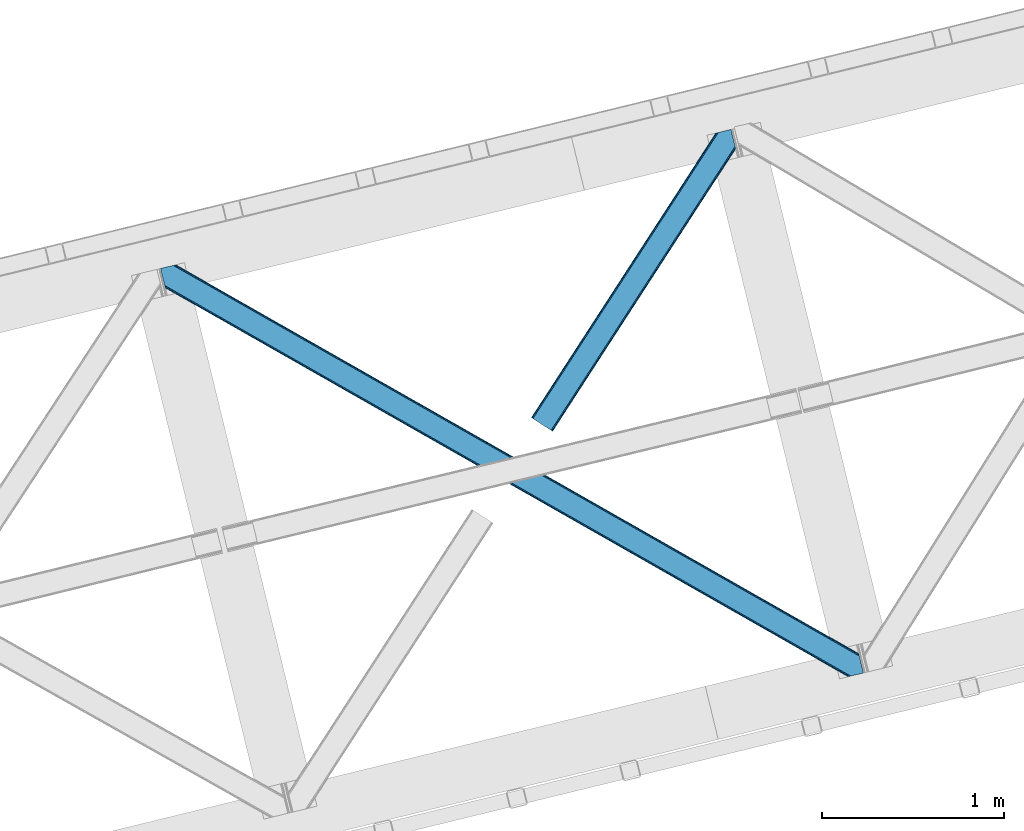
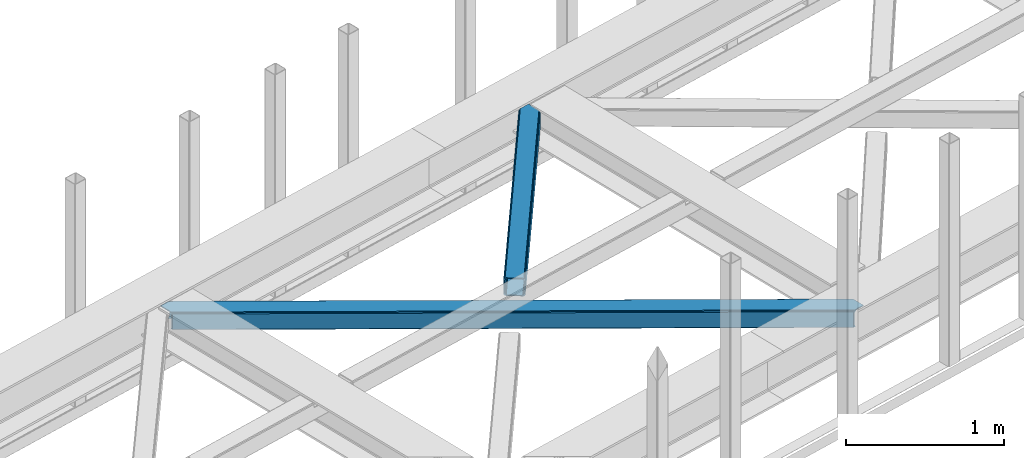
# One storey, part 37 of 67: 2 members.
"""IFC4 building model written with IfcOpenShell, lengths in millimetres."""

from ifc_helpers import new_model, entity, si_unit, converted_unit, derived_unit, direction, frame, origin, place, context, subcontext, project, spatial, triangles, type_object, element, save


model = new_model("IFC4")

# Units and contexts
model_context = context("Model", 3, precision=0.01, world=origin(), true_north=direction((6.12303176911189e-17, 1.0)))
plan_context = context("Plan", 3, precision=0.01, world=origin(), true_north=direction((6.12303176911189e-17, 1.0)))
body_context = subcontext(model_context, "Body", "Model", "MODEL_VIEW")
ifc_project = project(units=[si_unit("LENGTHUNIT", "METRE", prefix="MILLI"), si_unit("AREAUNIT", "SQUARE_METRE"), si_unit("VOLUMEUNIT", "CUBIC_METRE"), converted_unit("PLANEANGLEUNIT", "DEGREE", entity("IfcRatioMeasure", 0.0174532925199433), si_unit("PLANEANGLEUNIT", "RADIAN"), dimensions=[0, 0, 0, 0, 0, 0, 0]), si_unit("MASSUNIT", "GRAM", prefix="KILO"), derived_unit("MASSDENSITYUNIT", [(si_unit("MASSUNIT", "GRAM", prefix="KILO"), 1), (si_unit("LENGTHUNIT", "METRE"), -3)]), derived_unit("MOMENTOFINERTIAUNIT", [(si_unit("LENGTHUNIT", "METRE"), 4)]), si_unit("TIMEUNIT", "SECOND"), si_unit("FREQUENCYUNIT", "HERTZ"), si_unit("THERMODYNAMICTEMPERATUREUNIT", "DEGREE_CELSIUS"), derived_unit("THERMALTRANSMITTANCEUNIT", [(si_unit("MASSUNIT", "GRAM", prefix="KILO"), 1), (si_unit("THERMODYNAMICTEMPERATUREUNIT", "KELVIN"), -1), (si_unit("TIMEUNIT", "SECOND"), -3)]), derived_unit("VOLUMETRICFLOWRATEUNIT", [(si_unit("LENGTHUNIT", "METRE"), 3), (si_unit("TIMEUNIT", "SECOND"), -1)]), derived_unit("MASSFLOWRATEUNIT", [(si_unit("MASSUNIT", "GRAM", prefix="KILO"), 1), (si_unit("TIMEUNIT", "SECOND"), -1)]), derived_unit("ROTATIONALFREQUENCYUNIT", [(si_unit("TIMEUNIT", "SECOND"), -1)]), si_unit("ELECTRICCURRENTUNIT", "AMPERE"), si_unit("ELECTRICVOLTAGEUNIT", "VOLT"), si_unit("POWERUNIT", "WATT"), si_unit("FORCEUNIT", "NEWTON", prefix="KILO"), si_unit("ILLUMINANCEUNIT", "LUX"), si_unit("LUMINOUSFLUXUNIT", "LUMEN"), si_unit("LUMINOUSINTENSITYUNIT", "CANDELA"), derived_unit("USERDEFINED", [(si_unit("MASSUNIT", "GRAM", prefix="KILO"), -1), (si_unit("LENGTHUNIT", "METRE"), -2), (si_unit("TIMEUNIT", "SECOND"), 3), (si_unit("LUMINOUSFLUXUNIT", "LUMEN"), 1)]), derived_unit("LINEARVELOCITYUNIT", [(si_unit("LENGTHUNIT", "METRE"), 1), (si_unit("TIMEUNIT", "SECOND"), -1)]), si_unit("PRESSUREUNIT", "PASCAL"), derived_unit("USERDEFINED", [(si_unit("LENGTHUNIT", "METRE"), -2), (si_unit("MASSUNIT", "GRAM", prefix="KILO"), 1), (si_unit("TIMEUNIT", "SECOND"), -2)]), derived_unit("LINEARFORCEUNIT", [(si_unit("MASSUNIT", "GRAM", prefix="KILO"), 1), (si_unit("LENGTHUNIT", "METRE"), 1), (si_unit("TIMEUNIT", "SECOND"), -2), (si_unit("LENGTHUNIT", "METRE"), -1)]), derived_unit("PLANARFORCEUNIT", [(si_unit("MASSUNIT", "GRAM", prefix="KILO"), 1), (si_unit("LENGTHUNIT", "METRE"), 1), (si_unit("TIMEUNIT", "SECOND"), -2), (si_unit("LENGTHUNIT", "METRE"), -2)])], contexts=[model_context, plan_context])

# Site, building, storey
site_placement = place(None, origin())
site = spatial("IfcSite", under=ifc_project, at=site_placement, CompositionType="ELEMENT")
building_placement = place(site_placement, origin())
building = spatial("IfcBuilding", under=site, at=building_placement, CompositionType="ELEMENT")
storey_placement = place(building_placement, frame((0.0, 0.0, 19800.0)))
storey = spatial("IfcBuildingStorey", under=building, at=storey_placement, CompositionType="ELEMENT", Elevation=19800.0)

# Members
member_type_1 = type_object("IfcMemberType", PredefinedType="BRACE")
member_1_placement = place(storey_placement, frame((-33302.3207519531, 10419.121005249, 3823.05807495117)))
element("IfcMember", 1, at=member_1_placement, inside=storey, type_object=member_type_1, ObjectType="Steel Horizontal Brace", PredefinedType="BRACE", context=body_context, shape_type="Tessellation", body=[
    triangles([(3770.60705566406, 0.0, 122.478570556643), (3772.49298706055, 0.459274291992188, 129.175836181643), (25.7193603515625, 2133.71162109375, 130.119964599609), (26.1542175292998, 2131.93149719238, 123.422698974609), (3777.86242675781, 1.767333984375, 134.852233886719), (24.4845520019517, 2138.77991638184, 135.79868774414), (3785.89449462891, 3.72651672363281, 138.645025634767), (22.6358276367173, 2146.36666259766, 139.593804931643), (3795.37298583984, 6.03684082031214, 139.975177001954), (20.454565429689, 2155.31379089356, 140.926281738281), (1898.4864440918, 1065.90586853027, 17.9500671386741), (2530.61995239258, 705.99644165039, 17.7919372558608), (3162.75346069336, 346.087014770508, 17.631481933593), (3770.60705566406, 0.0, 17.478002929689), (1266.35293579102, 1425.81529541016, 18.1105224609382), (26.1542175292998, 2131.93149719238, 18.4221313476555), (634.22175292969, 1785.72355957031, 18.2686523437515), (3834.64500732422, 104.50408630371, 139.977502441408), (3855.09957275391, 20.5952545166019, 139.963549804688), (59.7242614746137, 2253.78103637695, 140.93093261719), (0.0, 2239.22262268066, 140.940234375001), (3832.46607055664, 113.452377319336, 138.647351074218), (69.2027526855454, 2256.09136047363, 139.596130371094), (3830.61502075195, 121.037960815429, 134.854559326173), (77.2371459960923, 2258.04938049316, 135.801013183594), (3829.38021240235, 126.106256103516, 129.178161621094), (82.6065856933637, 2259.35860290527, 130.122290039064), (3828.94535522461, 127.886380004882, 122.480895996094), (84.490191650395, 2259.81787719727, 123.425024414064), (3220.89642333984, 474.082690429686, 17.6338073730476), (3828.94535522461, 127.886380004882, 17.4803283691399), (2588.76291503906, 833.99211730957, 17.7942626953118), (1956.62940673828, 1193.90154418945, 17.9547180175796), (1324.4958984375, 1553.81097106934, 18.1128479003928), (692.364715576172, 1913.72156066894, 18.273303222657), (84.490191650395, 2259.81787719727, 18.4267822265647), (3832.89627685547, 111.685043334961, 127.852661132813), (3832.89627685547, 111.685043334961, 12.1039123535156), (3833.99853515625, 107.15973815918, 9.46221313476781), (3829.58020019531, 125.287701416015, 9.46221313476781), (3831.65914306641, 116.753338623046, 122.176263427737), (3834.7450012207, 104.098297119141, 131.645452880861), (3836.92626342774, 95.1500061035149, 132.975604248048), (3855.09957275391, 20.5952545166019, 132.963977050782), (3831.22661132813, 118.533462524414, 115.478997802737), (3831.22661132813, 118.533462524414, 24.4799011230461), (3831.65914306641, 116.753338623046, 17.7826354980461), (3829.47090454102, 125.737673950194, 10.8528259277336), (1952.50407714844, 1188.19607849121, 24.9542907714858), (74.5838195800825, 2257.4029083252, 116.427777099609), (2588.61641235352, 826.021673583984, 24.793835449218), (3224.72874755859, 463.846105957031, 24.6333801269539), (1316.39406738281, 1550.37164611816, 25.11474609375), (74.5838195800825, 2257.4029083252, 25.4263549804709), (680.279406738282, 1912.54721374512, 25.2752014160178), (72.7002136230512, 2256.9436340332, 123.125042724609), (67.3307739257798, 2255.63557434082, 128.803765869143), (59.2940551757856, 2253.67639160156, 132.598883056642), (49.8202148437485, 2251.36723022461, 133.931359863283), (0.0, 2239.22262268066, 133.940661621094), (67.3307739257798, 2255.63557434082, 13.0550170898459), (81.762451171875, 2259.1539642334, 10.4412231445313), (72.7002136230512, 2256.9436340332, 18.7314147949219), (62.6054809570342, 2254.4833190918, 10.4412231445313), (82.2252136230454, 2259.26558532715, 11.7946289062493), (3805.27935791016, 8.45180969238208, 132.973278808593), (18.1733093261719, 2164.66787109375, 133.929034423829), (3795.80319213867, 6.14148559570276, 131.643127441406), (20.3545715332075, 2155.71958007812, 132.594232177737), (3787.76879882813, 4.18230285644495, 127.850335693362), (22.2032958984419, 2148.13399658203, 128.799114990234), (3782.39935913086, 2.87424316406214, 122.173937988282), (23.4404296875, 2143.06453857422, 123.122717285158), (3780.51342773438, 2.41496887206995, 115.476672363282), (23.8729614257827, 2141.28441467285, 116.425451660158), (3174.86434936523, 347.246246337891, 24.6287292480483), (3780.51342773438, 2.41496887206995, 24.4775756835952), (2538.75433959961, 709.420651245116, 24.7891845703125), (1902.64200439453, 1071.59505615234, 24.9496398925803), (1266.52966918945, 1433.76946105957, 25.1100952148445), (630.417333984376, 1795.9438659668, 25.2705505371086), (23.8729614257827, 2141.28441467285, 25.4240295410164), (23.4404296875, 2143.06453857422, 18.7267639160164), (25.526348876956, 2134.50575866699, 10.4412231445313), (22.2032958984419, 2148.13399658203, 13.0503662109368), (25.6333190918012, 2134.06973876953, 11.7923034667983), (21.1173156738296, 2152.58837585449, 10.4412231445313), (3787.76879882813, 4.18230285644495, 12.1015869140647), (3773.35805053711, 0.669726562498909, 9.46221313476781), (3782.39935913086, 2.87424316406214, 17.7803100585952), (3792.55455322266, 5.34967346191297, 9.46221313476781), (3772.88133544922, 0.554617309569949, 10.8481750488281), (3697.37896728516, 59.5847351074208, 9.46221313476781), (3701.80660400391, 41.4207275390618, 9.46221313476781), (153.281341552734, 2218.44482116699, 10.4412231445313), (157.68107299805, 2200.39708557129, 10.4412231445313), (154.658001708987, 2217.02514038086, 9.4412841796875), (159.494915771487, 2197.17402648926, 9.4412841796875), (159.143774414064, 2198.29140014648, 9.82498168945313), (154.325463867186, 2217.3681427002, 9.68312988281468), (158.657757568362, 2198.98903198242, 10.0296203613289), (153.969671630861, 2217.73439941406, 9.94125366210938), (158.167089843751, 2199.69829101562, 10.2365844726555), (153.613879394536, 2218.10181884766, 10.1993774414077), (193.244018554688, 2054.50599060059, 10.4412231445313), (197.636773681639, 2036.48848571777, 10.4412231445313), (193.823052978514, 2056.35122680664, 9.4412841796875), (198.650665283203, 2036.54313354492, 9.4412841796875), (193.769567871095, 2055.7105682373, 9.74824218749927), (198.466955566408, 2036.45825500488, 9.74126586914281), (193.713757324222, 2055.05479431152, 10.0598510742202), (198.266967773438, 2036.36523742676, 10.0668273925803), (193.657946777348, 2054.41297302246, 10.366809082032), (198.078607177733, 2036.27919616699, 10.366809082032), (3701.47406616211, 41.764892578125, 9.22036743164063), (3696.87899780273, 60.0172668457035, 9.38547363281396), (3701.11827392578, 42.1334747314449, 8.96224365234593), (3696.43716430664, 60.9648834228519, 9.07851562500218), (3700.76248168945, 42.5032196044922, 8.7041198730476), (3695.99067993164, 61.9218017578114, 8.76923217773583), (3700.42994384766, 42.8473846435536, 8.46227416992406), (3695.54884643555, 62.8694183349598, 8.46227416992406), (3163.41156005859, 347.245083618163, 10.934216308593), (634.879852294922, 1786.8827911377, 11.5737121582024), (636.754156494142, 1790.1791015625, 5.89498901367188), (197.780950927736, 2040.11268310547, 6.0066101074226), (3165.28586425781, 350.542556762695, 5.25781860351708), (3699.57883300781, 46.3401947021484, 5.1229431152351), (3697.72778320313, 53.9257781982415, 1.33015136718677), (3168.09499511719, 355.4759765625, 1.46502685546875), (3695.5465209961, 62.8740692138672, 0.0), (3171.40874633789, 361.296551513671, 0.132550048827397), (642.877038574221, 1800.9342590332, 0.76972045898583), (639.563287353518, 1795.11368408203, 2.10219726562718), (195.932226562501, 2047.69826660156, 2.21381835937427), (193.750964355473, 2056.64655761719, 0.8836669921875), (2539.27523803711, 721.205978393555, 0.290679931640625), (2535.96148681641, 715.385403442382, 1.62315673828198), (1907.14172973633, 1081.11540527344, 0.451135253908433), (1903.82797851563, 1075.29483032227, 1.78361206054615), (1275.00822143555, 1441.02483215332, 0.609265136718022), (1271.69447021485, 1435.20425720215, 1.94174194335938), (2533.15235595703, 710.451983642577, 5.41594848633031), (1901.01884765625, 1070.36141052246, 5.57640380859448), (1268.88766479492, 1430.27083740234, 5.73685913085865), (2531.27805175781, 707.154510498047, 11.0946716308608), (1899.14454345703, 1067.06393737793, 11.2528015136741), (1267.01103515625, 1426.97336425781, 11.4132568359382), (3661.34860839844, 203.171319580078, 0.0209289550803078), (3212.23416137695, 458.877804565429, 0.134875488281978), (2580.10297851563, 818.787231445313, 0.293005371095205), (1947.96947021484, 1178.69665832519, 0.453460693359375), (683.702453613281, 1898.51551208496, 0.772045898436772), (1315.83596191406, 1538.60608520508, 0.613916015627183), (159.553051757815, 2196.9438079834, 0.904595947267808), (3177.39675292969, 351.70062561035, 12.2550659179688), (3180.20588378907, 356.635208129883, 8.46227416992406), (3695.44420166016, 63.299624633788, 8.39483642578125), (3693.26759033203, 72.2269866943352, 7.00189819336083), (639.072619628907, 1811.15340270996, 7.77161865234302), (191.472033691411, 2065.99947509766, 7.88323974609375), (193.643994140628, 2057.08722839356, 9.32268676758031), (632.952062988283, 1800.39940795898, 12.8968872070327), (635.758868408204, 1805.33399047852, 9.10409545898438), (631.075433349612, 1797.10309753418, 18.5756103515632), (3183.51963500977, 362.455783081054, 7.12979736328271), (3175.52244873047, 348.404315185546, 17.9337890624993), (2539.41011352539, 710.578720092773, 18.0942443847671), (1903.30010375977, 1072.753125, 18.2546997070313), (1267.18776855469, 1434.92752990723, 18.4151550292991), (2541.28674316406, 713.876193237304, 12.4155212402366), (1905.17440795898, 1076.05059814453, 12.5759765625007), (1269.06439819336, 1438.22500305176, 12.7364318847649), (2544.09587402344, 718.810775756836, 8.62272949218823), (1907.98353881836, 1080.98518066406, 8.7831848144524), (1271.87352905274, 1443.15958557129, 8.94364013672021), (2547.40962524414, 724.630187988281, 7.29025268554688), (1911.29729003906, 1086.80459289551, 7.45070800781468), (1275.18495483399, 1448.97899780273, 7.61116333007885), (155.520739746098, 2213.47884521484, 6.03218994140843), (157.37178955078, 2205.89209899902, 2.23707275390552), (161.831982421878, 2187.59089050293, 7.90416870117406), (159.657696533206, 2196.50778808594, 9.33431396484593), (3216.0664855957, 448.640057373046, 7.13212280273365), (2579.95647583008, 810.815624999999, 7.29257812500146), (1943.84181518555, 1172.99119262695, 7.45303344726563), (3663.6275390625, 193.818402099609, 7.02050170898656), (671.617144775391, 1897.34000244141, 7.7739440917976), (1307.72947998047, 1535.16559753418, 7.61348876953343), (3220.23832397461, 472.926947021484, 10.9365417480476), (3218.35704345703, 469.630636596679, 5.26014404296802), (3656.48843994141, 223.423571777343, 8.84597167968968), (3656.47216186524, 223.174749755859, 8.46227416992406), (3657.48372802735, 223.244512939453, 9.46221313476781), (3656.81400146485, 223.365435791015, 9.04595947265625), (3657.31862182617, 219.705194091797, 5.14852294922093), (691.704290771486, 1912.56465454101, 11.576037597657), (689.82533569336, 1909.26834411621, 5.89731445312646), (687.016204833984, 1904.33492431641, 2.10452270507813), (3659.16734619141, 212.119610595702, 1.3557312011726), (3215.54791259766, 464.697216796874, 1.46735229492333), (2588.10481567383, 832.836373901368, 11.0969970703118), (1955.97130737305, 1192.74580078125, 11.2574523925796), (1323.83779907227, 1552.65522766113, 11.4155822753928), (2586.22353515625, 829.540063476563, 5.42059936523583), (1954.09235229492, 1189.44949035644, 5.57872924804906), (1321.95884399414, 1549.35891723633, 5.73918457031323), (2583.41440429688, 824.606643676758, 1.62548217773656), (1951.28322143555, 1184.51607055664, 1.78593750000073), (1319.14971313477, 1544.42549743652, 1.94406738281396), (674.930895996094, 1903.16057739258, 9.10642089843896), (677.742352294925, 1908.09399719238, 12.8992126464836), (3661.36256103516, 203.10969543457, 8.46227416992406), (3661.92066650391, 205.049111938477, 9.46221313476781), (3222.19169311524, 459.394052124024, 12.2573913574233), (3219.38023681641, 454.459469604491, 8.464599609375), (3661.30209960938, 203.975921630859, 8.81574096679833), (3661.24396362305, 204.843310546874, 9.1692077636726), (679.618981933596, 1911.38914489746, 18.5779357910178), (3224.06832275391, 462.689199829101, 17.9361145019539), (2583.26790161133, 816.635037231445, 8.62505493164281), (1947.15556640625, 1178.8106048584, 8.78551025390698), (1311.04323120117, 1540.98500976563, 8.94596557617115), (2586.0770324707, 821.56845703125, 12.4178466796875), (1949.96469726563, 1183.74286193848, 12.5783020019553), (1313.8546875, 1545.91842956543, 12.7387573242195), (2587.95598754883, 824.864767456054, 18.096569824218), (1951.84365234375, 1187.04033508301, 18.2570251464858), (1315.73131713867, 1549.21473999023, 18.41748046875)], [[1, 2, 3], [3, 4, 1], [2, 5, 6], [6, 3, 2], [5, 7, 8], [8, 6, 5], [7, 9, 10], [10, 8, 7], [11, 1, 4], [1, 12, 13], [11, 12, 1], [13, 14, 1], [15, 11, 4], [4, 16, 17], [17, 15, 4], [9, 18, 10], [9, 19, 18], [20, 10, 18], [21, 10, 20], [18, 22, 23], [23, 20, 18], [22, 24, 25], [25, 23, 22], [24, 26, 27], [27, 25, 24], [26, 28, 29], [29, 27, 26], [30, 28, 31], [28, 30, 32], [28, 33, 29], [33, 28, 32], [29, 33, 34], [34, 35, 29], [36, 29, 35], [37, 24, 22], [38, 39, 40], [24, 37, 41], [42, 37, 22], [42, 18, 43], [19, 43, 18], [43, 19, 44], [42, 22, 18], [31, 45, 46], [40, 47, 38], [47, 31, 46], [48, 47, 40], [48, 31, 47], [28, 45, 31], [41, 26, 24], [28, 26, 41], [45, 28, 41], [49, 45, 50], [45, 51, 52], [49, 51, 45], [52, 46, 45], [53, 49, 50], [50, 54, 55], [55, 53, 50], [45, 41, 50], [56, 50, 41], [41, 37, 56], [57, 56, 37], [37, 42, 57], [58, 57, 42], [42, 43, 58], [59, 58, 43], [56, 29, 27], [58, 23, 20], [21, 59, 20], [59, 21, 60], [59, 58, 20], [57, 23, 58], [57, 56, 25], [25, 23, 57], [27, 25, 56], [54, 36, 29], [61, 62, 63], [56, 50, 29], [61, 64, 62], [54, 63, 36], [50, 54, 29], [65, 36, 63], [63, 62, 65], [43, 66, 67], [66, 43, 44], [67, 59, 43], [60, 59, 67], [66, 68, 67], [69, 67, 68], [68, 70, 69], [71, 69, 70], [70, 72, 71], [73, 71, 72], [72, 74, 73], [75, 73, 74], [76, 74, 77], [74, 76, 78], [74, 79, 75], [79, 74, 78], [75, 79, 80], [80, 81, 75], [82, 75, 81], [83, 84, 85], [82, 4, 16], [16, 86, 83], [86, 84, 83], [83, 82, 16], [75, 4, 82], [73, 71, 6], [3, 73, 6], [3, 4, 73], [75, 73, 4], [71, 8, 6], [69, 8, 71], [87, 85, 84], [69, 67, 10], [69, 10, 8], [67, 21, 10], [67, 60, 21], [72, 1, 2], [68, 7, 9], [66, 19, 44], [9, 66, 68], [66, 9, 19], [70, 7, 68], [70, 72, 5], [5, 7, 70], [2, 5, 72], [14, 1, 74], [88, 89, 90], [72, 74, 1], [88, 91, 89], [77, 90, 14], [77, 14, 74], [92, 14, 90], [90, 89, 92], [91, 89, 93], [94, 93, 89], [95, 96, 62], [64, 62, 96], [97, 98, 99], [100, 99, 101], [102, 101, 103], [104, 103, 96], [96, 95, 104], [103, 104, 102], [101, 102, 100], [99, 100, 97], [105, 106, 84], [84, 87, 105], [107, 108, 109], [110, 109, 108], [109, 110, 111], [112, 111, 110], [111, 112, 113], [114, 113, 112], [113, 114, 106], [106, 105, 113], [115, 116, 93], [117, 118, 116], [119, 120, 118], [121, 122, 120], [120, 119, 121], [118, 117, 119], [116, 115, 117], [93, 94, 115], [123, 92, 14], [124, 17, 16], [110, 125, 112], [110, 108, 125], [114, 112, 125], [108, 126, 125], [124, 86, 106], [106, 125, 124], [106, 114, 125], [86, 84, 106], [92, 123, 94], [123, 127, 128], [128, 121, 123], [115, 123, 117], [115, 94, 123], [123, 119, 117], [123, 121, 119], [94, 89, 92], [129, 128, 127], [127, 130, 129], [131, 129, 130], [130, 132, 131], [133, 134, 135], [135, 136, 133], [134, 125, 126], [126, 135, 134], [16, 86, 124], [14, 13, 123], [132, 130, 137], [138, 137, 130], [137, 138, 139], [140, 139, 138], [139, 140, 141], [142, 141, 140], [141, 142, 133], [134, 133, 142], [130, 127, 143], [143, 138, 130], [138, 143, 144], [144, 140, 138], [140, 144, 145], [145, 142, 140], [142, 145, 125], [125, 134, 142], [127, 123, 143], [146, 143, 123], [143, 146, 144], [147, 144, 146], [144, 147, 145], [148, 145, 147], [145, 148, 125], [124, 125, 148], [123, 13, 12], [12, 146, 123], [146, 12, 11], [11, 147, 146], [147, 11, 15], [15, 148, 147], [148, 15, 17], [17, 124, 148], [149, 131, 132], [150, 132, 137], [132, 150, 149], [151, 139, 152], [137, 151, 150], [151, 137, 139], [133, 153, 154], [152, 141, 154], [141, 152, 139], [141, 133, 154], [136, 153, 133], [155, 153, 136], [156, 116, 118], [118, 157, 156], [118, 120, 157], [122, 157, 120], [122, 158, 157], [88, 91, 93], [93, 156, 88], [93, 116, 156], [157, 158, 159], [160, 161, 162], [163, 113, 105], [105, 85, 163], [105, 87, 85], [164, 162, 107], [107, 163, 164], [163, 109, 111], [109, 163, 107], [111, 113, 163], [81, 165, 82], [83, 82, 165], [165, 163, 83], [85, 83, 163], [162, 164, 160], [159, 166, 157], [90, 88, 156], [156, 167, 90], [77, 90, 167], [167, 76, 77], [76, 167, 168], [168, 78, 76], [78, 168, 79], [169, 79, 168], [79, 169, 80], [170, 80, 169], [80, 170, 81], [165, 81, 170], [167, 156, 168], [171, 168, 156], [168, 171, 172], [172, 169, 168], [169, 172, 173], [173, 170, 169], [170, 173, 163], [163, 165, 170], [156, 157, 174], [174, 171, 156], [171, 174, 172], [175, 172, 174], [172, 175, 173], [176, 173, 175], [173, 176, 163], [164, 163, 176], [157, 166, 174], [177, 174, 166], [174, 177, 178], [178, 175, 174], [175, 178, 179], [179, 176, 175], [176, 179, 160], [160, 164, 176], [98, 180, 181], [155, 98, 181], [182, 183, 155], [182, 155, 161], [180, 98, 97], [155, 183, 98], [161, 136, 162], [136, 135, 107], [136, 161, 155], [126, 107, 135], [136, 107, 162], [126, 108, 107], [177, 166, 184], [184, 185, 177], [185, 178, 177], [178, 185, 186], [166, 187, 184], [166, 159, 187], [188, 160, 189], [160, 188, 161], [182, 161, 188], [179, 189, 160], [186, 179, 178], [189, 179, 186], [190, 30, 31], [191, 192, 193], [190, 48, 194], [194, 191, 190], [194, 195, 191], [48, 40, 194], [193, 196, 191], [65, 197, 95], [197, 198, 180], [180, 97, 197], [197, 97, 102], [102, 95, 197], [197, 65, 36], [36, 35, 197], [95, 62, 65], [198, 199, 181], [181, 180, 198], [199, 153, 155], [155, 181, 199], [200, 149, 150], [150, 201, 200], [196, 200, 201], [201, 191, 196], [31, 48, 190], [30, 190, 32], [202, 32, 190], [32, 202, 33], [203, 33, 202], [33, 203, 34], [204, 34, 203], [34, 204, 197], [197, 35, 34], [190, 191, 205], [205, 202, 190], [202, 205, 206], [206, 203, 202], [203, 206, 207], [207, 204, 203], [204, 207, 198], [198, 197, 204], [191, 201, 205], [208, 205, 201], [205, 208, 206], [209, 206, 208], [206, 209, 207], [210, 207, 209], [207, 210, 198], [199, 198, 210], [201, 150, 208], [151, 208, 150], [208, 151, 152], [152, 209, 208], [209, 152, 154], [154, 210, 209], [210, 154, 153], [153, 199, 210], [211, 99, 183], [212, 103, 101], [212, 96, 103], [101, 211, 212], [101, 99, 211], [61, 64, 96], [96, 212, 61], [211, 183, 182], [184, 187, 213], [214, 38, 215], [214, 39, 38], [213, 215, 216], [217, 218, 215], [215, 213, 217], [213, 216, 184], [182, 188, 211], [212, 219, 63], [63, 61, 212], [219, 55, 54], [54, 63, 219], [47, 46, 220], [52, 220, 46], [38, 47, 215], [220, 215, 47], [184, 216, 185], [221, 185, 216], [185, 221, 186], [222, 186, 221], [186, 222, 189], [223, 189, 222], [189, 223, 188], [211, 188, 223], [216, 215, 224], [224, 221, 216], [221, 224, 225], [225, 222, 221], [222, 225, 226], [226, 223, 222], [223, 226, 212], [212, 211, 223], [215, 220, 224], [227, 224, 220], [224, 227, 225], [228, 225, 227], [225, 228, 226], [229, 226, 228], [226, 229, 212], [219, 212, 229], [220, 52, 51], [51, 227, 220], [227, 51, 49], [49, 228, 227], [228, 49, 53], [53, 229, 228], [229, 53, 55], [55, 219, 229], [149, 187, 159], [213, 196, 193], [149, 213, 187], [213, 200, 196], [213, 149, 200], [131, 149, 159], [158, 131, 159], [128, 158, 121], [158, 129, 131], [158, 128, 129], [214, 217, 193], [217, 213, 193], [40, 39, 214], [214, 194, 40]]),
])
member_type_2 = type_object("IfcMemberType", PredefinedType="BRACE")
member_2_placement = place(storey_placement, frame((-31269.0378845215, 11764.6853851318, 3823.57664794922)))
element("IfcMember", 2, at=member_2_placement, inside=storey, type_object=member_type_2, ObjectType="Steel Horizontal Brace", PredefinedType="BRACE", context=body_context, shape_type="Tessellation", body=[
    triangles([(972.968518066409, 1545.29288635254, 0.386022949220205), (1007.16875610352, 1404.99563598633, 0.365093994139897), (14.7014282226592, 66.6447692871097, 0.0), (102.814654541016, 9.54011535644531, 0.0), (1.13248901367479, 75.4349304199222, 10.8039916992202), (0.011627197265625, 76.1581420898438, 17.4989318847656), (1010.67784423828, 1635.6559753418, 17.9082092285171), (968.503674316409, 1566.80901489258, 9.6808044433601), (4.31601562500146, 73.3734283447266, 5.12526855468604), (968.640875244142, 1567.26712646485, 9.92265014648365), (968.357171630862, 1566.32067260742, 9.42268066406177), (968.210668945314, 1565.83116760254, 9.16455688476708), (968.073468017581, 1565.37421875, 8.9227111816399), (968.938531494143, 1561.82676086426, 5.51361694336083), (1012.94282226563, 1636.20826721191, 11.2760559082017), (1013.40325927734, 1636.32105102539, 9.92265014648365), (970.787255859377, 1554.24117736817, 1.71849975585792), (9.07851562500218, 70.2864074707031, 1.33247680664135), (1010.67784423828, 1635.6559753418, 122.906451416016), (0.0, 76.1395385742198, 122.499499511719), (1012.56145019531, 1636.11524963379, 129.603717041016), (1.11853637695458, 75.4140014648438, 129.196765136719), (1017.92856445313, 1637.42330932617, 135.282440185547), (4.29973754883031, 73.3490112304698, 134.873162841795), (1025.96528320313, 1639.38249206543, 139.077557373046), (9.06456298828198, 70.2608276367191, 138.668280029298), (1035.44377441406, 1641.69281616211, 140.412359619142), (14.6828247070334, 66.6191894531257, 140.000756835936), (973.040606689454, 1549.21939086914, 9.92265014648365), (972.796435546876, 1548.6089630127, 9.84823608398438), (972.833642578127, 1547.58344421387, 9.5412780761726), (972.87317504883, 1546.54862365723, 9.22966918945167), (972.912707519532, 1545.5231048584, 8.9227111816399), (1032.56255493164, 1640.99053344727, 9.92265014648365), (14.9525756835938, 66.4773376464855, 8.3320495605476), (20.5754882812507, 62.8368621826176, 6.99957275390625), (975.249774169923, 1535.93996887207, 7.38559570312646), (10.1877502441421, 69.5655212402344, 12.1248413085923), (1027.83726196289, 1639.83827819824, 12.5364440917983), (973.075488281251, 1544.85570373535, 8.81574096679833), (1022.46782226563, 1638.53021850586, 18.2128417968743), (1020.58421630859, 1638.07094421387, 24.9077819824233), (7.00422363281541, 71.6270233154301, 17.8035644531265), (5.88568725586083, 72.3502349853516, 24.5008300781265), (1004.8875, 1414.3485534668, 7.36466674804615), (96.9382690429702, 13.3456970214847, 6.99957275390625), (1007.06178588867, 1405.4363067627, 8.80411376953271), (1007.24084472656, 1404.70030517578, 8.9227111816399), (1012.06845703125, 1384.89221191406, 8.9227111816399), (1011.19874267578, 1388.46176147461, 5.488037109375), (1009.35001831055, 1396.0473449707, 1.69524536132667), (1020.58421630859, 1638.07094421387, 115.909204101561), (5.87638549804979, 72.3339569091804, 115.499926757813), (1035.87398071289, 1641.7974609375, 132.080310058594), (1045.34782104492, 1644.10778503418, 133.412786865236), (20.5592102050796, 62.8124450683608, 132.998858642579), (14.9386230468772, 66.4552459716797, 131.668707275392), (1027.83726196289, 1639.83827819824, 128.285192871095), (10.1737976074219, 69.5434295654304, 127.873590087889), (1022.46782226563, 1638.53021850586, 122.606469726561), (6.99259643554979, 71.6084197998061, 122.197192382813), (1095.16803588867, 1656.2512298584, 140.421661376953), (1095.16803588867, 1656.2512298584, 133.422088623047), (1115.62260131836, 1572.34239807129, 140.407708740233), (102.798376464845, 9.5145355224613, 140.000756835936), (1113.34134521485, 1581.69647827149, 133.410461425781), (96.92431640625, 13.3224426269535, 132.998858642579), (1117.80153808594, 1563.39526977539, 139.075231933595), (108.418963623048, 5.87289733886792, 138.668280029298), (1119.65258789063, 1555.80852355957, 135.280114746092), (113.181463623048, 2.78587646484448, 134.873162841795), (1120.88739624024, 1550.74022827148, 129.601391601562), (116.36731567383, 0.72321166992333, 129.196765136719), (1121.32225341797, 1548.96010437012, 122.904125976562), (117.485852050784, 0.0, 122.499499511719), (1121.32225341797, 1548.96010437012, 17.9035583496079), (117.499804687501, 0.0197662353530177, 17.4989318847656), (107.309729003908, 6.59378356933667, 127.873590087889), (110.495581054689, 4.53228149414099, 122.197192382813), (111.611791992189, 3.80790710449219, 115.499926757813), (102.544903564456, 9.6808044433601, 131.668707275392), (116.38126831055, 0.74530334472729, 10.8039916992202), (107.323681640628, 6.61471252441515, 12.1248413085923), (113.197741699219, 2.80913085937573, 5.12526855468604), (111.623419189455, 3.82534790039063, 24.5008300781265), (110.507208251955, 4.55088500976672, 17.8035644531265), (108.432916259768, 5.89731445312646, 1.33247680664135), (102.558856201173, 9.70289611816406, 8.3320495605476), (1118.60846557617, 1560.09314575195, 122.60414428711), (1119.04099731446, 1558.31302185059, 115.90687866211), (1117.37133178711, 1565.16260375977, 128.280541992186), (1115.52260742188, 1572.74818725586, 132.075659179689), (1119.04099731446, 1558.31302185059, 24.9054565429688), (1118.60846557617, 1560.09314575195, 18.2081909179688), (1120.69438476563, 1551.53436584473, 9.92265014648365), (1117.37133178711, 1565.16260375977, 12.5317932128892), (1120.79902954102, 1551.09834594727, 11.2737304687507), (1116.2853515625, 1569.61698303223, 9.92265014648365), (1012.19868164063, 1384.68524780274, 9.30640869140552), (1012.7358581543, 1385.10731506348, 9.72266235351708), (1012.99630737305, 1385.31079101563, 9.92265014648365), (1008.6035522461, 1403.32829589844, 9.92265014648365), (1007.57570800781, 1403.93872375488, 9.27617797851417)], [[1, 2, 3], [4, 3, 2], [5, 6, 7], [8, 9, 10], [9, 8, 11], [12, 9, 11], [9, 12, 13], [13, 14, 9], [5, 15, 10], [10, 9, 5], [15, 16, 10], [17, 1, 18], [3, 18, 1], [14, 17, 9], [18, 9, 17], [7, 15, 5], [19, 7, 20], [6, 20, 7], [21, 19, 22], [20, 22, 19], [23, 21, 24], [22, 24, 21], [25, 23, 26], [24, 26, 23], [27, 25, 28], [26, 28, 25], [8, 10, 29], [11, 8, 30], [12, 11, 31], [13, 12, 32], [32, 33, 13], [31, 32, 12], [30, 31, 11], [29, 30, 8], [16, 34, 29], [29, 10, 16], [35, 36, 37], [38, 30, 29], [29, 39, 38], [29, 34, 39], [38, 35, 40], [40, 33, 38], [31, 38, 32], [31, 30, 38], [38, 33, 32], [37, 40, 35], [41, 42, 43], [44, 43, 42], [39, 41, 38], [43, 38, 41], [45, 37, 36], [36, 46, 45], [1, 37, 45], [13, 33, 14], [33, 40, 1], [37, 1, 40], [33, 17, 14], [33, 1, 17], [2, 1, 45], [2, 45, 47], [48, 2, 47], [49, 50, 48], [48, 51, 2], [48, 50, 51], [42, 52, 53], [53, 44, 42], [54, 55, 56], [56, 57, 54], [58, 54, 57], [57, 59, 58], [60, 58, 59], [59, 61, 60], [52, 60, 61], [61, 53, 52], [60, 19, 21], [54, 25, 27], [62, 55, 27], [55, 62, 63], [55, 54, 27], [58, 25, 54], [58, 60, 23], [23, 25, 58], [21, 23, 60], [42, 7, 19], [39, 16, 41], [60, 52, 19], [39, 34, 16], [42, 41, 7], [52, 42, 19], [15, 7, 41], [41, 16, 15], [64, 27, 28], [27, 64, 62], [28, 65, 64], [55, 66, 56], [55, 63, 66], [67, 56, 66], [68, 64, 65], [65, 69, 68], [70, 68, 69], [69, 71, 70], [72, 70, 71], [71, 73, 72], [74, 72, 73], [73, 75, 74], [76, 74, 75], [75, 77, 76], [73, 78, 79], [80, 77, 75], [73, 79, 75], [73, 71, 78], [79, 80, 75], [78, 71, 69], [67, 65, 28], [65, 81, 69], [81, 65, 67], [81, 78, 69], [82, 83, 84], [85, 77, 80], [77, 86, 82], [86, 77, 85], [82, 86, 83], [4, 46, 3], [87, 84, 83], [83, 88, 87], [88, 46, 4], [4, 87, 88], [59, 26, 24], [28, 56, 67], [28, 57, 56], [57, 28, 26], [59, 57, 26], [53, 20, 6], [22, 61, 59], [24, 22, 59], [61, 22, 20], [53, 61, 20], [18, 38, 9], [3, 46, 36], [36, 35, 3], [35, 38, 18], [18, 3, 35], [5, 9, 38], [6, 44, 53], [43, 6, 5], [6, 43, 44], [43, 5, 38], [89, 90, 79], [80, 79, 90], [91, 89, 78], [79, 78, 89], [92, 91, 81], [78, 81, 91], [66, 92, 67], [81, 67, 92], [90, 93, 80], [85, 80, 93], [94, 95, 96], [93, 74, 76], [76, 97, 94], [97, 95, 94], [94, 93, 76], [90, 74, 93], [89, 91, 70], [72, 89, 70], [72, 74, 89], [90, 89, 74], [91, 68, 70], [92, 68, 91], [98, 96, 95], [92, 66, 64], [92, 64, 68], [66, 62, 64], [66, 63, 62], [82, 97, 76], [82, 99, 100], [101, 97, 82], [101, 95, 97], [84, 50, 99], [99, 82, 84], [51, 50, 87], [84, 87, 50], [2, 51, 4], [87, 4, 51], [76, 77, 82], [102, 103, 88], [48, 88, 103], [83, 96, 102], [102, 88, 83], [96, 98, 102], [46, 88, 48], [48, 45, 46], [94, 96, 83], [83, 86, 94], [93, 94, 86], [86, 85, 93], [99, 48, 103], [99, 103, 102], [98, 95, 102], [101, 102, 95]]),
])

save(model, "model.ifc")
